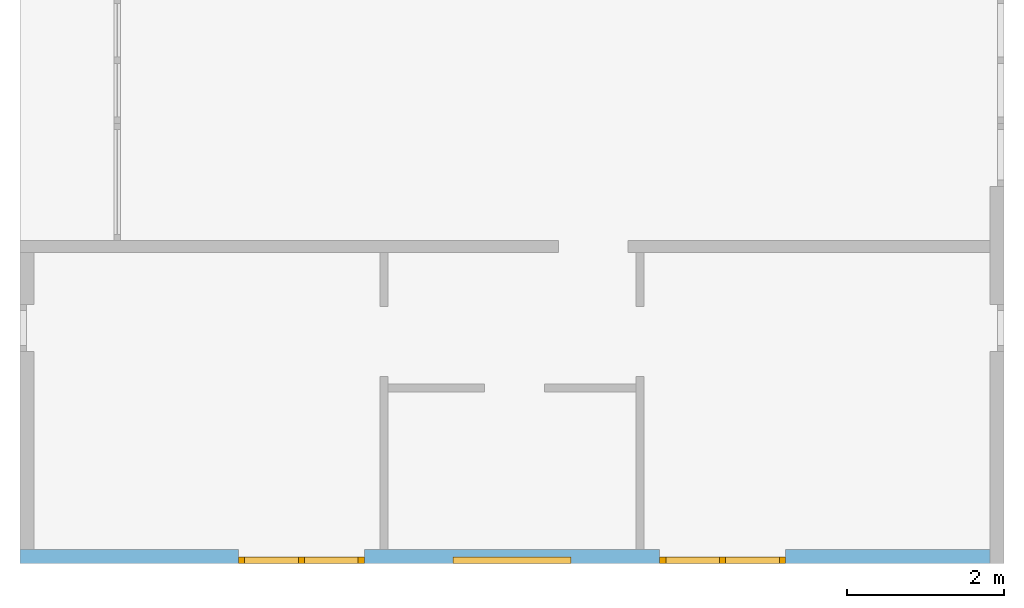
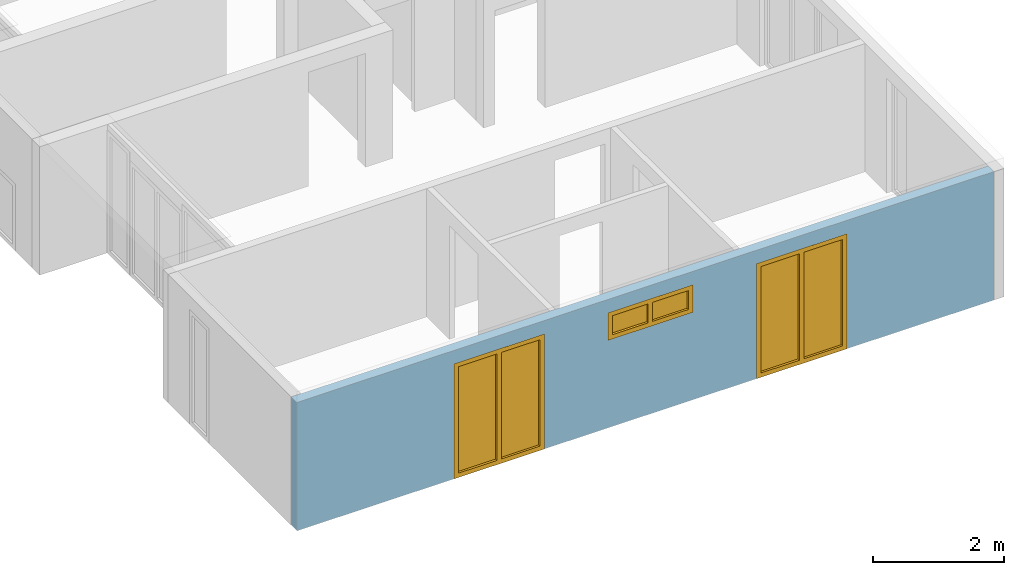
# One storey, part 3 of 8: 3 windows, 3 openings, plus 1 element that does not belong to this part.
"""IFC2X3 building model written with IfcOpenShell, lengths in millimetres."""

from ifc_helpers import new_model, entity, si_unit, converted_unit, frame, frame_2d, origin, origin_with_axes, place, context, project, spatial, rectangle, extrude, faceted_brep, material, layer, layer_set, layer_usage, element, fill, save


model = new_model("IFC2X3")

# Units and contexts
model_context = context("Model", 3, precision=1e-05, world=origin())
plan_context = context("Plan", 3, precision=1e-05, world=origin())
ifc_project = project(units=[si_unit("LENGTHUNIT", "METRE", prefix="MILLI"), converted_unit("PLANEANGLEUNIT", "DEGREE", entity("IfcPlaneAngleMeasure", 0.0174532925199433), si_unit("PLANEANGLEUNIT", "RADIAN"), dimensions=[0, 0, 0, 0, 0, 0, 0]), si_unit("AREAUNIT", "SQUARE_METRE"), si_unit("VOLUMEUNIT", "CUBIC_METRE")], contexts=[model_context, plan_context])

# Building, storey
building_placement = place(None, origin())
building = spatial("IfcBuilding", under=ifc_project, at=building_placement, CompositionType="ELEMENT")
storey_placement = place(building_placement, frame((0.0, 0.0, 2900.0), z_axis=(0.0, 0.0, 1.0), x_axis=(1.0, 0.0, 0.0)))
storey = spatial("IfcBuildingStorey", under=building, at=storey_placement, Name="OG", CompositionType="ELEMENT", Elevation=2900.0)

# Wall, openings, windows
ifc_material_1 = material(Name="B25")
ifc_layer = layer(ifc_material_1, 175.0)
ifc_layer_set = layer_set([ifc_layer])
ifc_layer_usage = layer_usage(ifc_layer_set, "AXIS2", "POSITIVE", 0.0)
wall_placement = place(storey_placement, frame((21188.3517822139, -8691.5625, 0.0), z_axis=(0.0, 0.0, 1.0), x_axis=(1.0, 0.0, 0.0)))
wall = element("IfcWallStandardCase", 1, at=wall_placement, inside=storey, material=ifc_layer_usage, context=model_context, shape_type="SweptSolid", body=[
    extrude(rectangle(XDim=12324.9999999553, YDim=175.0, at=frame_2d((6162.49999997765, 87.5), x_axis=(1.0, 0.0))), origin_with_axes(), (0.0, 0.0, 1.0), 2400.0),
])
opening_1_placement = place(wall_placement, frame((5499.99999998852, 0.0, 1635.0), z_axis=(0.0, 1.0, 0.0), x_axis=(0.0, 0.0, 1.0)))
opening_1 = element("IfcOpeningElement", 2, at=opening_1_placement, cuts=wall, ObjectType="Opening", context=model_context, shape_type="SweptSolid", body=[
    extrude(rectangle(XDim=515.0, YDim=1500.0, at=frame_2d((257.5, 750.0), x_axis=(1.0, 0.0))), origin_with_axes(), (0.0, 0.0, 1.0), 175.0),
])
opening_2_placement = place(wall_placement, frame((2775.00178047279, 0.0, 0.0), z_axis=(0.0, 1.0, 0.0), x_axis=(0.0, 0.0, 1.0)))
opening_2 = element("IfcOpeningElement", 3, at=opening_2_placement, cuts=wall, ObjectType="Opening", context=model_context, shape_type="SweptSolid", body=[
    extrude(rectangle(XDim=2150.0, YDim=1600.0, at=frame_2d((1075.0, 800.0), x_axis=(1.0, 0.0))), origin_with_axes(), (0.0, 0.0, 1.0), 175.0),
])
opening_3_placement = place(wall_placement, frame((8124.9982195274, 0.0, 0.0), z_axis=(0.0, 1.0, 0.0), x_axis=(0.0, 0.0, 1.0)))
opening_3 = element("IfcOpeningElement", 4, at=opening_3_placement, cuts=wall, ObjectType="Opening", context=model_context, shape_type="SweptSolid", body=[
    extrude(rectangle(XDim=2150.0, YDim=1600.0, at=frame_2d((1075.0, 800.0), x_axis=(1.0, 0.0))), origin_with_axes(), (0.0, 0.0, 1.0), 175.0),
])
ifc_material_2 = material()
window_1_placement = place(opening_1_placement, frame((0.0, 0.0, 0.0), z_axis=(1.0, 0.0, 0.0), x_axis=(0.0, 1.0, 0.0)))
window_1 = element("IfcWindow", 5, at=window_1_placement, inside=storey, material=ifc_material_2, Name="m", OverallHeight=515.0, OverallWidth=1500.0, context=model_context, shape_type="Brep", body=[
    faceted_brep([(80.0, 4.28888036196895e-11, 0.0), (0.0, 4.28986846046087e-11, 0.0), (0.0, 4.28986846046087e-11, 515.0), (80.0, 4.28888036196895e-11, 515.0), (0.0, 80.0000000000429, 0.0), (80.0, 80.0000000000429, 0.0), (80.0, 80.0000000000429, 515.0), (0.0, 80.0000000000429, 515.0), (0.0, 4.28986846046087e-11, 0.0), (80.0, 4.28888036196895e-11, 0.0), (80.0, 80.0000000000429, 0.0), (0.0, 80.0000000000429, 0.0), (0.0, 4.28986846046087e-11, 515.0), (0.0, 4.28986846046087e-11, 0.0), (0.0, 80.0000000000429, 0.0), (0.0, 80.0000000000429, 515.0), (80.0, 4.28888036196895e-11, 515.0), (0.0, 4.28986846046087e-11, 515.0), (0.0, 80.0000000000429, 515.0), (80.0, 80.0000000000429, 515.0), (80.0, 4.28888036196895e-11, 0.0), (80.0, 4.28888036196895e-11, 515.0), (80.0, 80.0000000000429, 515.0), (80.0, 80.0000000000429, 0.0)], [[[0, 1, 2, 3]], [[4, 5, 6, 7]], [[8, 9, 10, 11]], [[12, 13, 14, 15]], [[16, 17, 18, 19]], [[20, 21, 22, 23]]], orient=[[False], [False], [False], [False], [False], [False]]),
    faceted_brep([(1420.0, 4.26962909472195e-11, 515.0), (1500.0, 4.26865209846028e-11, 515.0), (1500.0, 4.26865209846028e-11, 0.0), (1420.0, 4.26962909472195e-11, 0.0), (1500.0, 80.0000000000427, 515.0), (1420.0, 80.0000000000427, 515.0), (1420.0, 80.0000000000427, 0.0), (1500.0, 80.0000000000427, 0.0), (1500.0, 4.26865209846028e-11, 515.0), (1420.0, 4.26962909472195e-11, 515.0), (1420.0, 80.0000000000427, 515.0), (1500.0, 80.0000000000427, 515.0), (1500.0, 4.26865209846028e-11, 0.0), (1500.0, 4.26865209846028e-11, 515.0), (1500.0, 80.0000000000427, 515.0), (1500.0, 80.0000000000427, 0.0), (1420.0, 4.26962909472195e-11, 0.0), (1500.0, 4.26865209846028e-11, 0.0), (1500.0, 80.0000000000427, 0.0), (1420.0, 80.0000000000427, 0.0), (1420.0, 4.26962909472195e-11, 515.0), (1420.0, 4.26962909472195e-11, 0.0), (1420.0, 80.0000000000427, 0.0), (1420.0, 80.0000000000427, 515.0)], [[[0, 1, 2, 3]], [[4, 5, 6, 7]], [[8, 9, 10, 11]], [[12, 13, 14, 15]], [[16, 17, 18, 19]], [[20, 21, 22, 23]]], orient=[[False], [False], [False], [False], [False], [False]]),
    faceted_brep([(1420.0, 4.26998436608983e-11, 80.0), (1420.0, 4.26998436608983e-11, 0.0), (80.0, 4.28639346239379e-11, 0.0), (80.0, 4.28639346239379e-11, 80.0), (1420.0, 80.0000000000427, 0.0), (1420.0, 80.0000000000427, 80.0), (80.0, 80.0000000000428, 80.0), (80.0, 80.0000000000428, 0.0), (1420.0, 4.26998436608983e-11, 0.0), (1420.0, 4.26998436608983e-11, 80.0), (1420.0, 80.0000000000427, 80.0), (1420.0, 80.0000000000427, 0.0), (80.0, 4.28639346239379e-11, 0.0), (1420.0, 4.26998436608983e-11, 0.0), (1420.0, 80.0000000000427, 0.0), (80.0, 80.0000000000428, 0.0), (80.0, 4.28639346239379e-11, 80.0), (80.0, 4.28639346239379e-11, 0.0), (80.0, 80.0000000000428, 0.0), (80.0, 80.0000000000428, 80.0), (1420.0, 4.26998436608983e-11, 80.0), (80.0, 4.28639346239379e-11, 80.0), (80.0, 80.0000000000428, 80.0), (1420.0, 80.0000000000427, 80.0)], [[[0, 1, 2, 3]], [[4, 5, 6, 7]], [[8, 9, 10, 11]], [[12, 13, 14, 15]], [[16, 17, 18, 19]], [[20, 21, 22, 23]]], orient=[[False], [False], [False], [False], [False], [False]]),
    faceted_brep([(80.0, 4.28639346239379e-11, 435.0), (80.0, 4.28639346239379e-11, 515.0), (1420.0, 4.26998436608983e-11, 515.0), (1420.0, 4.26998436608983e-11, 435.0), (80.0, 80.0000000000428, 515.0), (80.0, 80.0000000000428, 435.0), (1420.0, 80.0000000000427, 435.0), (1420.0, 80.0000000000427, 515.0), (80.0, 4.28639346239379e-11, 515.0), (80.0, 4.28639346239379e-11, 435.0), (80.0, 80.0000000000428, 435.0), (80.0, 80.0000000000428, 515.0), (1420.0, 4.26998436608983e-11, 515.0), (80.0, 4.28639346239379e-11, 515.0), (80.0, 80.0000000000428, 515.0), (1420.0, 80.0000000000427, 515.0), (1420.0, 4.26998436608983e-11, 435.0), (1420.0, 4.26998436608983e-11, 515.0), (1420.0, 80.0000000000427, 515.0), (1420.0, 80.0000000000427, 435.0), (80.0, 4.28639346239379e-11, 435.0), (1420.0, 4.26998436608983e-11, 435.0), (1420.0, 80.0000000000427, 435.0), (80.0, 80.0000000000428, 435.0)], [[[0, 1, 2, 3]], [[4, 5, 6, 7]], [[8, 9, 10, 11]], [[12, 13, 14, 15]], [[16, 17, 18, 19]], [[20, 21, 22, 23]]], orient=[[False], [False], [False], [False], [False], [False]]),
    faceted_brep([(790.0, 4.27876623021461e-11, 80.0), (710.0, 4.27974322647628e-11, 80.0), (710.0, 4.27974322647628e-11, 435.0), (790.0, 4.27876623021461e-11, 435.0), (710.0, 80.0000000000428, 80.0), (790.0, 80.0000000000428, 80.0), (790.0, 80.0000000000428, 435.0), (710.0, 80.0000000000428, 435.0), (710.0, 4.27974322647628e-11, 80.0), (790.0, 4.27876623021461e-11, 80.0), (790.0, 80.0000000000428, 80.0), (710.0, 80.0000000000428, 80.0), (710.0, 4.27974322647628e-11, 435.0), (710.0, 4.27974322647628e-11, 80.0), (710.0, 80.0000000000428, 80.0), (710.0, 80.0000000000428, 435.0), (790.0, 4.27876623021461e-11, 435.0), (710.0, 4.27974322647628e-11, 435.0), (710.0, 80.0000000000428, 435.0), (790.0, 80.0000000000428, 435.0), (790.0, 4.27876623021461e-11, 80.0), (790.0, 4.27876623021461e-11, 435.0), (790.0, 80.0000000000428, 435.0), (790.0, 80.0000000000428, 80.0)], [[[0, 1, 2, 3]], [[4, 5, 6, 7]], [[8, 9, 10, 11]], [[12, 13, 14, 15]], [[16, 17, 18, 19]], [[20, 21, 22, 23]]], orient=[[False], [False], [False], [False], [False], [False]]),
    faceted_brep([(1420.0, 40.0000000000427, 435.0), (1420.0, 40.0000000000427, 80.0), (790.0, 40.0000000000428, 80.0), (790.0, 40.0000000000428, 435.0), (1420.0, 41.0000000000427, 435.0), (790.0, 41.0000000000428, 435.0), (790.0, 41.0000000000428, 80.0), (1420.0, 41.0000000000427, 80.0), (1420.0, 40.0000000000427, 435.0), (1420.0, 41.0000000000427, 435.0), (1420.0, 41.0000000000427, 80.0), (1420.0, 40.0000000000427, 80.0), (1420.0, 40.0000000000427, 80.0), (1420.0, 41.0000000000427, 80.0), (790.0, 41.0000000000428, 80.0), (790.0, 40.0000000000428, 80.0), (790.0, 40.0000000000428, 80.0), (790.0, 41.0000000000428, 80.0), (790.0, 41.0000000000428, 435.0), (790.0, 40.0000000000428, 435.0), (790.0, 40.0000000000428, 435.0), (790.0, 41.0000000000428, 435.0), (1420.0, 41.0000000000427, 435.0), (1420.0, 40.0000000000427, 435.0)], [[[0, 1, 2, 3]], [[4, 5, 6, 7]], [[8, 9, 10, 11]], [[12, 13, 14, 15]], [[16, 17, 18, 19]], [[20, 21, 22, 23]]], orient=[[False], [False], [False], [False], [False], [False]]),
    faceted_brep([(710.0, 40.0000000000428, 435.0), (710.0, 40.0000000000428, 80.0), (80.0, 40.0000000000429, 80.0), (80.0, 40.0000000000429, 435.0), (710.0, 41.0000000000428, 435.0), (80.0, 41.0000000000429, 435.0), (80.0, 41.0000000000429, 80.0), (710.0, 41.0000000000428, 80.0), (710.0, 40.0000000000428, 435.0), (710.0, 41.0000000000428, 435.0), (710.0, 41.0000000000428, 80.0), (710.0, 40.0000000000428, 80.0), (710.0, 40.0000000000428, 80.0), (710.0, 41.0000000000428, 80.0), (80.0, 41.0000000000429, 80.0), (80.0, 40.0000000000429, 80.0), (80.0, 40.0000000000429, 80.0), (80.0, 41.0000000000429, 80.0), (80.0, 41.0000000000429, 435.0), (80.0, 40.0000000000429, 435.0), (80.0, 40.0000000000429, 435.0), (80.0, 41.0000000000429, 435.0), (710.0, 41.0000000000428, 435.0), (710.0, 40.0000000000428, 435.0)], [[[0, 1, 2, 3]], [[4, 5, 6, 7]], [[8, 9, 10, 11]], [[12, 13, 14, 15]], [[16, 17, 18, 19]], [[20, 21, 22, 23]]], orient=[[False], [False], [False], [False], [False], [False]]),
])
fill(opening_1, window_1)
ifc_material_3 = material()
window_2_placement = place(opening_2_placement, frame((0.0, 0.0, 0.0), z_axis=(1.0, 0.0, 0.0), x_axis=(0.0, 1.0, 0.0)))
window_2 = element("IfcWindow", 6, at=window_2_placement, inside=storey, material=ifc_material_3, Name="m", OverallHeight=2150.0, OverallWidth=1600.0, context=model_context, shape_type="Brep", body=[
    faceted_brep([(80.0, 4.37675451436803e-11, 0.0), (0.0, 4.3777315106297e-11, 0.0), (0.0, 4.3777315106297e-11, 2150.0), (80.0, 4.37675451436803e-11, 2150.0), (0.0, 80.0000000000438, 0.0), (80.0, 80.0000000000438, 0.0), (80.0, 80.0000000000438, 2150.0), (0.0, 80.0000000000438, 2150.0), (0.0, 4.3777315106297e-11, 0.0), (80.0, 4.37675451436803e-11, 0.0), (80.0, 80.0000000000438, 0.0), (0.0, 80.0000000000438, 0.0), (0.0, 4.3777315106297e-11, 2150.0), (0.0, 4.3777315106297e-11, 0.0), (0.0, 80.0000000000438, 0.0), (0.0, 80.0000000000438, 2150.0), (80.0, 4.37675451436803e-11, 2150.0), (0.0, 4.3777315106297e-11, 2150.0), (0.0, 80.0000000000438, 2150.0), (80.0, 80.0000000000438, 2150.0), (80.0, 4.37675451436803e-11, 0.0), (80.0, 4.37675451436803e-11, 2150.0), (80.0, 80.0000000000438, 2150.0), (80.0, 80.0000000000438, 0.0)], [[[0, 1, 2, 3]], [[4, 5, 6, 7]], [[8, 9, 10, 11]], [[12, 13, 14, 15]], [[16, 17, 18, 19]], [[20, 21, 22, 23]]], orient=[[False], [False], [False], [False], [False], [False]]),
    faceted_brep([(1520.0, 4.35769198503522e-11, 2150.0), (1600.0, 4.35671498877355e-11, 2150.0), (1600.0, 4.35671498877355e-11, 0.0), (1520.0, 4.35769198503522e-11, 0.0), (1600.0, 80.0000000000436, 2150.0), (1520.0, 80.0000000000436, 2150.0), (1520.0, 80.0000000000436, 0.0), (1600.0, 80.0000000000436, 0.0), (1600.0, 4.35671498877355e-11, 2150.0), (1520.0, 4.35769198503522e-11, 2150.0), (1520.0, 80.0000000000436, 2150.0), (1600.0, 80.0000000000436, 2150.0), (1600.0, 4.35671498877355e-11, 0.0), (1600.0, 4.35671498877355e-11, 2150.0), (1600.0, 80.0000000000436, 2150.0), (1600.0, 80.0000000000436, 0.0), (1520.0, 4.35769198503522e-11, 0.0), (1600.0, 4.35671498877355e-11, 0.0), (1600.0, 80.0000000000436, 0.0), (1520.0, 80.0000000000436, 0.0), (1520.0, 4.35769198503522e-11, 2150.0), (1520.0, 4.35769198503522e-11, 0.0), (1520.0, 80.0000000000436, 0.0), (1520.0, 80.0000000000436, 2150.0)], [[[0, 1, 2, 3]], [[4, 5, 6, 7]], [[8, 9, 10, 11]], [[12, 13, 14, 15]], [[16, 17, 18, 19]], [[20, 21, 22, 23]]], orient=[[False], [False], [False], [False], [False], [False]]),
    faceted_brep([(1520.0, 4.3562708995637e-11, 80.0), (1520.0, 4.3562708995637e-11, 0.0), (80.0, 4.37391234342499e-11, 0.0), (80.0, 4.37391234342499e-11, 80.0), (1520.0, 80.0000000000436, 0.0), (1520.0, 80.0000000000436, 80.0), (80.0, 80.0000000000437, 80.0), (80.0, 80.0000000000437, 0.0), (1520.0, 4.3562708995637e-11, 0.0), (1520.0, 4.3562708995637e-11, 80.0), (1520.0, 80.0000000000436, 80.0), (1520.0, 80.0000000000436, 0.0), (80.0, 4.37391234342499e-11, 0.0), (1520.0, 4.3562708995637e-11, 0.0), (1520.0, 80.0000000000436, 0.0), (80.0, 80.0000000000437, 0.0), (80.0, 4.37391234342499e-11, 80.0), (80.0, 4.37391234342499e-11, 0.0), (80.0, 80.0000000000437, 0.0), (80.0, 80.0000000000437, 80.0), (1520.0, 4.3562708995637e-11, 80.0), (80.0, 4.37391234342499e-11, 80.0), (80.0, 80.0000000000437, 80.0), (1520.0, 80.0000000000436, 80.0)], [[[0, 1, 2, 3]], [[4, 5, 6, 7]], [[8, 9, 10, 11]], [[12, 13, 14, 15]], [[16, 17, 18, 19]], [[20, 21, 22, 23]]], orient=[[False], [False], [False], [False], [False], [False]]),
    faceted_brep([(80.0, 4.37391234342499e-11, 2070.0), (80.0, 4.37391234342499e-11, 2150.0), (1520.0, 4.3562708995637e-11, 2150.0), (1520.0, 4.3562708995637e-11, 2070.0), (80.0, 80.0000000000437, 2150.0), (80.0, 80.0000000000437, 2070.0), (1520.0, 80.0000000000436, 2070.0), (1520.0, 80.0000000000436, 2150.0), (80.0, 4.37391234342499e-11, 2150.0), (80.0, 4.37391234342499e-11, 2070.0), (80.0, 80.0000000000437, 2070.0), (80.0, 80.0000000000437, 2150.0), (1520.0, 4.3562708995637e-11, 2150.0), (80.0, 4.37391234342499e-11, 2150.0), (80.0, 80.0000000000437, 2150.0), (1520.0, 80.0000000000436, 2150.0), (1520.0, 4.3562708995637e-11, 2070.0), (1520.0, 4.3562708995637e-11, 2150.0), (1520.0, 80.0000000000436, 2150.0), (1520.0, 80.0000000000436, 2070.0), (80.0, 4.37391234342499e-11, 2070.0), (1520.0, 4.3562708995637e-11, 2070.0), (1520.0, 80.0000000000436, 2070.0), (80.0, 80.0000000000437, 2070.0)], [[[0, 1, 2, 3]], [[4, 5, 6, 7]], [[8, 9, 10, 11]], [[12, 13, 14, 15]], [[16, 17, 18, 19]], [[20, 21, 22, 23]]], orient=[[False], [False], [False], [False], [False], [False]]),
    faceted_brep([(840.0, 4.36921610003083e-11, 80.0), (760.0, 4.37020419852274e-11, 80.0), (760.0, 4.37020419852274e-11, 2070.0), (840.0, 4.36921610003083e-11, 2070.0), (760.0, 80.0000000000437, 80.0), (840.0, 80.0000000000437, 80.0), (840.0, 80.0000000000437, 2070.0), (760.0, 80.0000000000437, 2070.0), (760.0, 4.37020419852274e-11, 80.0), (840.0, 4.36921610003083e-11, 80.0), (840.0, 80.0000000000437, 80.0), (760.0, 80.0000000000437, 80.0), (760.0, 4.37020419852274e-11, 2070.0), (760.0, 4.37020419852274e-11, 80.0), (760.0, 80.0000000000437, 80.0), (760.0, 80.0000000000437, 2070.0), (840.0, 4.36921610003083e-11, 2070.0), (760.0, 4.37020419852274e-11, 2070.0), (760.0, 80.0000000000437, 2070.0), (840.0, 80.0000000000437, 2070.0), (840.0, 4.36921610003083e-11, 80.0), (840.0, 4.36921610003083e-11, 2070.0), (840.0, 80.0000000000437, 2070.0), (840.0, 80.0000000000437, 80.0)], [[[0, 1, 2, 3]], [[4, 5, 6, 7]], [[8, 9, 10, 11]], [[12, 13, 14, 15]], [[16, 17, 18, 19]], [[20, 21, 22, 23]]], orient=[[False], [False], [False], [False], [False], [False]]),
    faceted_brep([(1520.0, 40.0000000000436, 2070.0), (1520.0, 40.0000000000436, 80.0), (840.0, 40.0000000000437, 80.0), (840.0, 40.0000000000437, 2070.0), (1520.0, 41.0000000000436, 2070.0), (840.0, 41.0000000000437, 2070.0), (840.0, 41.0000000000437, 80.0), (1520.0, 41.0000000000436, 80.0), (1520.0, 40.0000000000436, 2070.0), (1520.0, 41.0000000000436, 2070.0), (1520.0, 41.0000000000436, 80.0), (1520.0, 40.0000000000436, 80.0), (1520.0, 40.0000000000436, 80.0), (1520.0, 41.0000000000436, 80.0), (840.0, 41.0000000000437, 80.0), (840.0, 40.0000000000437, 80.0), (840.0, 40.0000000000437, 80.0), (840.0, 41.0000000000437, 80.0), (840.0, 41.0000000000437, 2070.0), (840.0, 40.0000000000437, 2070.0), (840.0, 40.0000000000437, 2070.0), (840.0, 41.0000000000437, 2070.0), (1520.0, 41.0000000000436, 2070.0), (1520.0, 40.0000000000436, 2070.0)], [[[0, 1, 2, 3]], [[4, 5, 6, 7]], [[8, 9, 10, 11]], [[12, 13, 14, 15]], [[16, 17, 18, 19]], [[20, 21, 22, 23]]], orient=[[False], [False], [False], [False], [False], [False]]),
    faceted_brep([(760.0, 40.0000000000437, 2070.0), (760.0, 40.0000000000437, 80.0), (80.0, 40.0000000000438, 80.0), (80.0, 40.0000000000438, 2070.0), (760.0, 41.0000000000437, 2070.0), (80.0, 41.0000000000438, 2070.0), (80.0, 41.0000000000438, 80.0), (760.0, 41.0000000000437, 80.0), (760.0, 40.0000000000437, 2070.0), (760.0, 41.0000000000437, 2070.0), (760.0, 41.0000000000437, 80.0), (760.0, 40.0000000000437, 80.0), (760.0, 40.0000000000437, 80.0), (760.0, 41.0000000000437, 80.0), (80.0, 41.0000000000438, 80.0), (80.0, 40.0000000000438, 80.0), (80.0, 40.0000000000438, 80.0), (80.0, 41.0000000000438, 80.0), (80.0, 41.0000000000438, 2070.0), (80.0, 40.0000000000438, 2070.0), (80.0, 40.0000000000438, 2070.0), (80.0, 41.0000000000438, 2070.0), (760.0, 41.0000000000437, 2070.0), (760.0, 40.0000000000437, 2070.0)], [[[0, 1, 2, 3]], [[4, 5, 6, 7]], [[8, 9, 10, 11]], [[12, 13, 14, 15]], [[16, 17, 18, 19]], [[20, 21, 22, 23]]], orient=[[False], [False], [False], [False], [False], [False]]),
])
fill(opening_2, window_2)
ifc_material_4 = material()
window_3_placement = place(opening_3_placement, frame((0.0, 0.0, 0.0), z_axis=(1.0, 0.0, 0.0), x_axis=(0.0, 1.0, 0.0)))
window_3 = element("IfcWindow", 7, at=window_3_placement, inside=storey, material=ifc_material_4, Name="m", OverallHeight=2150.0, OverallWidth=1600.0, context=model_context, shape_type="Brep", body=[
    faceted_brep([(1520.0, 4.33667546317906e-11, 0.0), (1520.0, 4.33667546317906e-11, 2150.0), (1600.0, 4.33569846691739e-11, 2150.0), (1600.0, 4.33569846691739e-11, 0.0), (1600.0, 80.0000000000434, 0.0), (1600.0, 80.0000000000434, 2150.0), (1520.0, 80.0000000000434, 2150.0), (1520.0, 80.0000000000434, 0.0), (1600.0, 4.33569846691739e-11, 0.0), (1600.0, 80.0000000000434, 0.0), (1520.0, 80.0000000000434, 0.0), (1520.0, 4.33667546317906e-11, 0.0), (1600.0, 4.33569846691739e-11, 2150.0), (1600.0, 80.0000000000434, 2150.0), (1600.0, 80.0000000000434, 0.0), (1600.0, 4.33569846691739e-11, 0.0), (1520.0, 4.33667546317906e-11, 2150.0), (1520.0, 80.0000000000434, 2150.0), (1600.0, 80.0000000000434, 2150.0), (1600.0, 4.33569846691739e-11, 2150.0), (1520.0, 4.33667546317906e-11, 0.0), (1520.0, 80.0000000000434, 0.0), (1520.0, 80.0000000000434, 2150.0), (1520.0, 4.33667546317906e-11, 2150.0)], [[[0, 1, 2, 3]], [[4, 5, 6, 7]], [[8, 9, 10, 11]], [[12, 13, 14, 15]], [[16, 17, 18, 19]], [[20, 21, 22, 23]]], orient=[[False], [False], [False], [False], [False], [False]]),
    faceted_brep([(80.0, 4.35573799251188e-11, 2150.0), (80.0, 4.35573799251188e-11, 0.0), (-7.34763812276152e-17, 4.35671498877355e-11, 0.0), (-7.34763812276152e-17, 4.35671498877355e-11, 2150.0), (9.7233744493514e-15, 80.0000000000436, 2150.0), (9.7233744493514e-15, 80.0000000000436, 0.0), (80.0, 80.0000000000436, 0.0), (80.0, 80.0000000000436, 2150.0), (-7.34763812276152e-17, 4.35671498877355e-11, 2150.0), (9.7233744493514e-15, 80.0000000000436, 2150.0), (80.0, 80.0000000000436, 2150.0), (80.0, 4.35573799251188e-11, 2150.0), (-7.34763812276152e-17, 4.35671498877355e-11, 0.0), (9.7233744493514e-15, 80.0000000000436, 0.0), (9.7233744493514e-15, 80.0000000000436, 2150.0), (-7.34763812276152e-17, 4.35671498877355e-11, 2150.0), (80.0, 4.35573799251188e-11, 0.0), (80.0, 80.0000000000436, 0.0), (9.7233744493514e-15, 80.0000000000436, 0.0), (-7.34763812276152e-17, 4.35671498877355e-11, 0.0), (80.0, 4.35573799251188e-11, 2150.0), (80.0, 80.0000000000436, 2150.0), (80.0, 80.0000000000436, 0.0), (80.0, 4.35573799251188e-11, 0.0)], [[[0, 1, 2, 3]], [[4, 5, 6, 7]], [[8, 9, 10, 11]], [[12, 13, 14, 15]], [[16, 17, 18, 19]], [[20, 21, 22, 23]]], orient=[[False], [False], [False], [False], [False], [False]]),
    faceted_brep([(1520.0, 4.3395176341221e-11, 2070.0), (80.0, 4.3571590779834e-11, 2070.0), (80.0, 4.3571590779834e-11, 2150.0), (1520.0, 4.3395176341221e-11, 2150.0), (1520.0, 80.0000000000434, 2150.0), (80.0, 80.0000000000436, 2150.0), (80.0, 80.0000000000436, 2070.0), (1520.0, 80.0000000000434, 2070.0), (1520.0, 4.3395176341221e-11, 2150.0), (1520.0, 80.0000000000434, 2150.0), (1520.0, 80.0000000000434, 2070.0), (1520.0, 4.3395176341221e-11, 2070.0), (80.0, 4.3571590779834e-11, 2150.0), (80.0, 80.0000000000436, 2150.0), (1520.0, 80.0000000000434, 2150.0), (1520.0, 4.3395176341221e-11, 2150.0), (80.0, 4.3571590779834e-11, 2070.0), (80.0, 80.0000000000436, 2070.0), (80.0, 80.0000000000436, 2150.0), (80.0, 4.3571590779834e-11, 2150.0), (1520.0, 4.3395176341221e-11, 2070.0), (1520.0, 80.0000000000434, 2070.0), (80.0, 80.0000000000436, 2070.0), (80.0, 4.3571590779834e-11, 2070.0)], [[[0, 1, 2, 3]], [[4, 5, 6, 7]], [[8, 9, 10, 11]], [[12, 13, 14, 15]], [[16, 17, 18, 19]], [[20, 21, 22, 23]]], orient=[[False], [False], [False], [False], [False], [False]]),
    faceted_brep([(80.0, 4.3571590779834e-11, 80.0), (1520.0, 4.3395176341221e-11, 80.0), (1520.0, 4.3395176341221e-11, 0.0), (80.0, 4.3571590779834e-11, 0.0), (80.0, 80.0000000000436, 0.0), (1520.0, 80.0000000000434, 0.0), (1520.0, 80.0000000000434, 80.0), (80.0, 80.0000000000436, 80.0), (80.0, 4.3571590779834e-11, 0.0), (80.0, 80.0000000000436, 0.0), (80.0, 80.0000000000436, 80.0), (80.0, 4.3571590779834e-11, 80.0), (1520.0, 4.3395176341221e-11, 0.0), (1520.0, 80.0000000000434, 0.0), (80.0, 80.0000000000436, 0.0), (80.0, 4.3571590779834e-11, 0.0), (1520.0, 4.3395176341221e-11, 80.0), (1520.0, 80.0000000000434, 80.0), (1520.0, 80.0000000000434, 0.0), (1520.0, 4.3395176341221e-11, 0.0), (80.0, 4.3571590779834e-11, 80.0), (80.0, 80.0000000000436, 80.0), (1520.0, 80.0000000000434, 80.0), (1520.0, 4.3395176341221e-11, 80.0)], [[[0, 1, 2, 3]], [[4, 5, 6, 7]], [[8, 9, 10, 11]], [[12, 13, 14, 15]], [[16, 17, 18, 19]], [[20, 21, 22, 23]]], orient=[[False], [False], [False], [False], [False], [False]]),
    faceted_brep([(760.0, 4.34883240529871e-11, 80.0), (760.0, 4.34883240529871e-11, 2070.0), (840.0, 4.34784430680679e-11, 2070.0), (840.0, 4.34784430680679e-11, 80.0), (840.0, 80.0000000000435, 80.0), (840.0, 80.0000000000435, 2070.0), (760.0, 80.0000000000435, 2070.0), (760.0, 80.0000000000435, 80.0), (840.0, 4.34784430680679e-11, 80.0), (840.0, 80.0000000000435, 80.0), (760.0, 80.0000000000435, 80.0), (760.0, 4.34883240529871e-11, 80.0), (840.0, 4.34784430680679e-11, 2070.0), (840.0, 80.0000000000435, 2070.0), (840.0, 80.0000000000435, 80.0), (840.0, 4.34784430680679e-11, 80.0), (760.0, 4.34883240529871e-11, 2070.0), (760.0, 80.0000000000435, 2070.0), (840.0, 80.0000000000435, 2070.0), (840.0, 4.34784430680679e-11, 2070.0), (760.0, 4.34883240529871e-11, 80.0), (760.0, 80.0000000000435, 80.0), (760.0, 80.0000000000435, 2070.0), (760.0, 4.34883240529871e-11, 2070.0)], [[[0, 1, 2, 3]], [[4, 5, 6, 7]], [[8, 9, 10, 11]], [[12, 13, 14, 15]], [[16, 17, 18, 19]], [[20, 21, 22, 23]]], orient=[[False], [False], [False], [False], [False], [False]]),
    faceted_brep([(80.0, 40.0000000000436, 2070.0), (760.0, 40.0000000000435, 2070.0), (760.0, 40.0000000000435, 80.0), (80.0, 40.0000000000436, 80.0), (80.0, 41.0000000000436, 2070.0), (80.0, 41.0000000000436, 80.0), (760.0, 41.0000000000435, 80.0), (760.0, 41.0000000000435, 2070.0), (80.0, 40.0000000000436, 2070.0), (80.0, 41.0000000000436, 2070.0), (760.0, 41.0000000000435, 2070.0), (760.0, 40.0000000000435, 2070.0), (760.0, 40.0000000000435, 2070.0), (760.0, 41.0000000000435, 2070.0), (760.0, 41.0000000000435, 80.0), (760.0, 40.0000000000435, 80.0), (760.0, 40.0000000000435, 80.0), (760.0, 41.0000000000435, 80.0), (80.0, 41.0000000000436, 80.0), (80.0, 40.0000000000436, 80.0), (80.0, 40.0000000000436, 80.0), (80.0, 41.0000000000436, 80.0), (80.0, 41.0000000000436, 2070.0), (80.0, 40.0000000000436, 2070.0)], [[[0, 1, 2, 3]], [[4, 5, 6, 7]], [[8, 9, 10, 11]], [[12, 13, 14, 15]], [[16, 17, 18, 19]], [[20, 21, 22, 23]]], orient=[[False], [False], [False], [False], [False], [False]]),
    faceted_brep([(1520.0, 40.0000000000434, 80.0), (840.0, 40.0000000000435, 80.0), (840.0, 40.0000000000435, 2070.0), (1520.0, 40.0000000000434, 2070.0), (1520.0, 41.0000000000434, 80.0), (1520.0, 41.0000000000434, 2070.0), (840.0, 41.0000000000435, 2070.0), (840.0, 41.0000000000435, 80.0), (1520.0, 40.0000000000434, 80.0), (1520.0, 41.0000000000434, 80.0), (840.0, 41.0000000000435, 80.0), (840.0, 40.0000000000435, 80.0), (840.0, 40.0000000000435, 80.0), (840.0, 41.0000000000435, 80.0), (840.0, 41.0000000000435, 2070.0), (840.0, 40.0000000000435, 2070.0), (840.0, 40.0000000000435, 2070.0), (840.0, 41.0000000000435, 2070.0), (1520.0, 41.0000000000434, 2070.0), (1520.0, 40.0000000000434, 2070.0), (1520.0, 40.0000000000434, 2070.0), (1520.0, 41.0000000000434, 2070.0), (1520.0, 41.0000000000434, 80.0), (1520.0, 40.0000000000434, 80.0)], [[[0, 1, 2, 3]], [[4, 5, 6, 7]], [[8, 9, 10, 11]], [[12, 13, 14, 15]], [[16, 17, 18, 19]], [[20, 21, 22, 23]]], orient=[[False], [False], [False], [False], [False], [False]]),
])
fill(opening_3, window_3)

save(model, "model.ifc")
